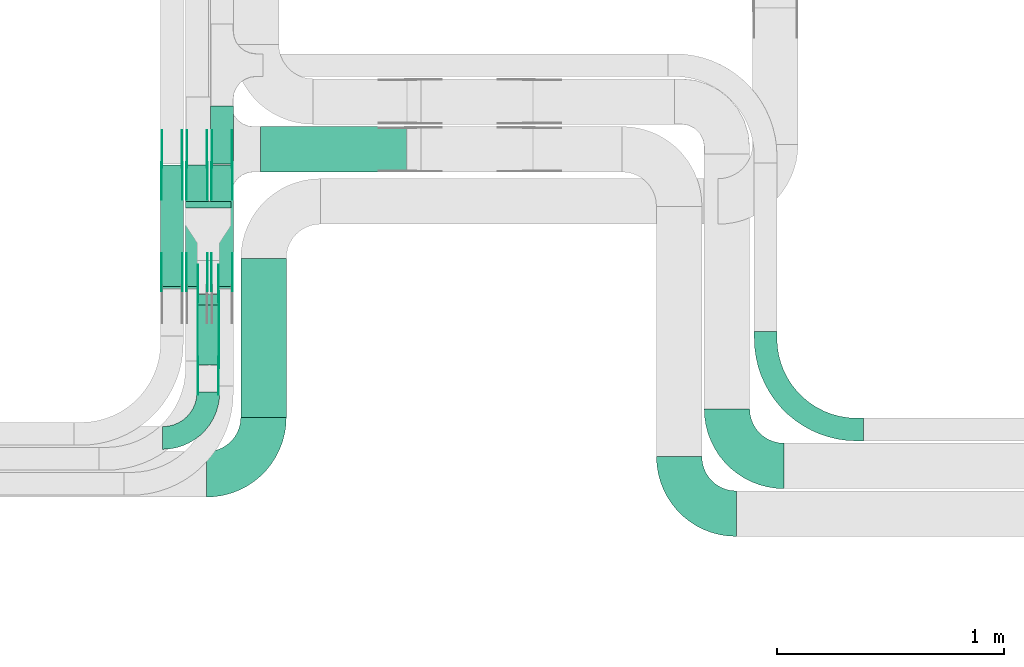
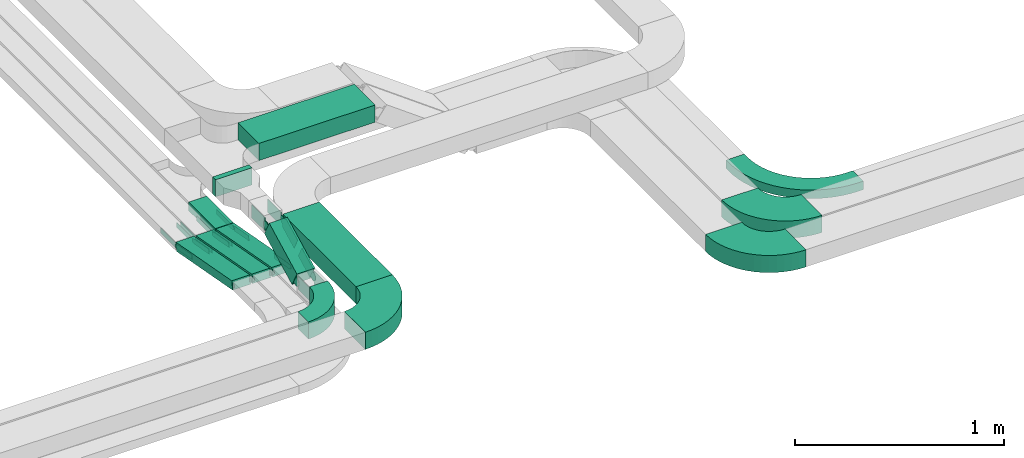
# One storey, part 10 of 25: 31 flow fittings, 8 flow segments.
"""IFC2X3 building model written with IfcOpenShell, lengths in millimetres."""

from ifc_helpers import new_model, entity, si_unit, converted_unit, derived_unit, direction, frame, frame_2d, origin, origin_2d_with_axis, place, context, subcontext, project, spatial, polyline, circle_curve, parameter, trimmed, segment, composite_curve, rectangle, outline, extrude, source, transform, mapped, material, type_object, type_shapes, element, save


model = new_model("IFC2X3")

# Units and contexts
model_context = context("Model", 3, precision=0.01, world=origin(), true_north=direction((6.12303176911189e-17, 1.0)))
body_context = subcontext(model_context, "Body", "Model", "MODEL_VIEW")
ifc_project = project(units=[si_unit("LENGTHUNIT", "METRE", prefix="MILLI"), si_unit("AREAUNIT", "SQUARE_METRE"), si_unit("VOLUMEUNIT", "CUBIC_METRE"), converted_unit("PLANEANGLEUNIT", "DEGREE", entity("IfcRatioMeasure", 0.0174532925199433), si_unit("PLANEANGLEUNIT", "RADIAN"), dimensions=[0, 0, 0, 0, 0, 0, 0]), si_unit("MASSUNIT", "GRAM", prefix="KILO"), derived_unit("MASSDENSITYUNIT", [(si_unit("MASSUNIT", "GRAM", prefix="KILO"), 1), (si_unit("LENGTHUNIT", "METRE"), -3)]), derived_unit("MOMENTOFINERTIAUNIT", [(si_unit("LENGTHUNIT", "METRE"), 4)]), si_unit("TIMEUNIT", "SECOND"), si_unit("FREQUENCYUNIT", "HERTZ"), si_unit("THERMODYNAMICTEMPERATUREUNIT", "DEGREE_CELSIUS"), derived_unit("THERMALTRANSMITTANCEUNIT", [(si_unit("MASSUNIT", "GRAM", prefix="KILO"), 1), (si_unit("THERMODYNAMICTEMPERATUREUNIT", "KELVIN"), -1), (si_unit("TIMEUNIT", "SECOND"), -3)]), derived_unit("VOLUMETRICFLOWRATEUNIT", [(si_unit("LENGTHUNIT", "METRE"), 3), (si_unit("TIMEUNIT", "SECOND"), -1)]), derived_unit("MASSFLOWRATEUNIT", [(si_unit("MASSUNIT", "GRAM", prefix="KILO"), 1), (si_unit("TIMEUNIT", "SECOND"), -1)]), derived_unit("ROTATIONALFREQUENCYUNIT", [(si_unit("TIMEUNIT", "SECOND"), -1)]), si_unit("ELECTRICCURRENTUNIT", "AMPERE"), si_unit("ELECTRICVOLTAGEUNIT", "VOLT"), si_unit("POWERUNIT", "WATT"), si_unit("FORCEUNIT", "NEWTON", prefix="KILO"), si_unit("ILLUMINANCEUNIT", "LUX"), si_unit("LUMINOUSFLUXUNIT", "LUMEN"), si_unit("LUMINOUSINTENSITYUNIT", "CANDELA"), derived_unit("USERDEFINED", [(si_unit("MASSUNIT", "GRAM", prefix="KILO"), -1), (si_unit("LENGTHUNIT", "METRE"), -2), (si_unit("TIMEUNIT", "SECOND"), 3), (si_unit("LUMINOUSFLUXUNIT", "LUMEN"), 1)]), derived_unit("LINEARVELOCITYUNIT", [(si_unit("LENGTHUNIT", "METRE"), 1), (si_unit("TIMEUNIT", "SECOND"), -1)]), si_unit("PRESSUREUNIT", "PASCAL"), derived_unit("USERDEFINED", [(si_unit("LENGTHUNIT", "METRE"), -2), (si_unit("MASSUNIT", "GRAM", prefix="KILO"), 1), (si_unit("TIMEUNIT", "SECOND"), -2)]), derived_unit("LINEARFORCEUNIT", [(si_unit("MASSUNIT", "GRAM", prefix="KILO"), 1), (si_unit("LENGTHUNIT", "METRE"), 1), (si_unit("TIMEUNIT", "SECOND"), -2), (si_unit("LENGTHUNIT", "METRE"), -1)]), derived_unit("PLANARFORCEUNIT", [(si_unit("MASSUNIT", "GRAM", prefix="KILO"), 1), (si_unit("LENGTHUNIT", "METRE"), 1), (si_unit("TIMEUNIT", "SECOND"), -2), (si_unit("LENGTHUNIT", "METRE"), -2)])], contexts=[model_context])

# Site, building, storey
site_placement = place(None, frame((0.0, -0.00077364408347762, 0.0)))
site = spatial("IfcSite", under=ifc_project, at=site_placement, CompositionType="ELEMENT")
building_placement = place(site_placement, origin())
building = spatial("IfcBuilding", under=site, at=building_placement, CompositionType="ELEMENT")
storey_placement = place(building_placement, frame((0.0, 0.0, 24000.0)))
storey = spatial("IfcBuildingStorey", under=building, at=storey_placement, CompositionType="ELEMENT", Elevation=24000.0)

# Flow segments
cable_carrier_segment_type = type_object("IfcCableCarrierSegmentType", PredefinedType="CABLETRAYSEGMENT")
flow_segment_1_placement = place(storey_placement, frame((33053.0827924389, 10611.4765215059, 2650.04095576845)))
element("IfcFlowSegment", 1, at=flow_segment_1_placement, inside=storey, type_object=cable_carrier_segment_type, context=body_context, shape_type="SweptSolid", body=[
    extrude(rectangle(XDim=255.423874591191, YDim=100.000000000003, at=frame_2d((1.08002495835535e-12, -2.16715534406831e-12), x_axis=(1.0, 0.0))), frame((50.0, 127.711937295601, 0.0), z_axis=(0.0, 0.0, 1.0), x_axis=(0.0, -1.0, 0.0)), (0.0, 0.0, 1.0), 49.9999999999973),
])
flow_segment_2_placement = place(storey_placement, frame((32833.0827924389, 10064.8940567036, 2651.07777631369)))
element("IfcFlowSegment", 2, at=flow_segment_2_placement, inside=storey, type_object=cable_carrier_segment_type, context=body_context, shape_type="SweptSolid", body=[
    extrude(rectangle(XDim=49.999999999997, YDim=543.827941763907, at=frame_2d((-1.05160324892495e-12, -1.93622895494627e-13), x_axis=(0.0, 1.0))), frame((0.0, 271.936643524978, 73.9222236863096), z_axis=(1.0, 0.0, 0.0), x_axis=(0.0, 0.983401255749196, -0.18144412415646)), (0.0, 0.0, 1.0), 100.000000000003),
])
for number, where in (
    (3, (32943.0827924389, 10064.8940567036, 2651.07777631369)),
    (4, (33053.0827924389, 10064.8940567036, 2651.07777631369)),
):
    element("IfcFlowSegment", number, at=place(storey_placement, frame(where)), inside=storey, type_object=cable_carrier_segment_type, context=body_context, shape_type="SweptSolid", body=[
        extrude(rectangle(XDim=49.999999999997, YDim=543.8279417639, at=frame_2d((0.0, 0.0), x_axis=(0.0, 1.0))), frame((0.0, 271.936643524971, 73.9222236863096), z_axis=(1.0, 0.0, 0.0), x_axis=(0.0, 0.983401255749195, -0.181444124156462)), (0.0, 0.0, 1.0), 100.000000000003),
    ])
flow_segment_3_placement = place(storey_placement, frame((32943.0827924389, 10418.7124766457, 3040.0)))
element("IfcFlowSegment", 5, at=flow_segment_3_placement, inside=storey, type_object=cable_carrier_segment_type, context=body_context, shape_type="SweptSolid", body=[
    extrude(rectangle(XDim=28.1879194516785, YDim=199.999999999998, at=frame_2d((1.08268949361445e-12, 4.33431068813661e-12), x_axis=(1.0, 0.0))), frame((100.0, 14.0939597258404, 0.0), z_axis=(0.0, 0.0, 1.0), x_axis=(0.0, -1.0, 0.0)), (0.0, 0.0, 1.0), 100.000000000003),
])
flow_segment_4_placement = place(storey_placement, frame((33273.0827924389, 10576.9003960973, 3040.0)))
element("IfcFlowSegment", 6, at=flow_segment_4_placement, inside=storey, type_object=cable_carrier_segment_type, context=body_context, shape_type="SweptSolid", body=[
    extrude(rectangle(XDim=641.371886509749, YDim=200.000000000002, at=frame_2d((2.1600499167107e-12, 1.08713038571295e-12), x_axis=(1.0, 0.0))), frame((320.685943254872, 100.0, 0.0)), (0.0, 0.0, 1.0), 100.000000000008),
])
flow_segment_5_placement = place(storey_placement, frame((32993.082792439, 9729.37885631118, 2902.16180601824)))
element("IfcFlowSegment", 7, at=flow_segment_5_placement, inside=storey, type_object=cable_carrier_segment_type, context=body_context, shape_type="SweptSolid", body=[
    extrude(rectangle(XDim=100.000000000008, YDim=100.000000000003, at=origin_2d_with_axis()), frame((50.0, 23.0412932838562, 44.3745287727967), z_axis=(0.0, 0.887490575455865, 0.460825865677067), x_axis=(0.0, -0.460825865677067, 0.887490575455865)), (0.0, 0.0, 1.0), 297.134645895809),
])
flow_segment_6_placement = place(storey_placement, frame((33185.8855251231, 9498.82356382277, 2890.0)))
element("IfcFlowSegment", 8, at=flow_segment_6_placement, inside=storey, type_object=cable_carrier_segment_type, context=body_context, shape_type="SweptSolid", body=[
    extrude(rectangle(XDim=698.000000000018, YDim=199.999999999998, at=frame_2d((-5.40012479177676e-13, 0.0), x_axis=(1.0, 0.0))), frame((100.0, 349.0, 0.0), z_axis=(0.0, 0.0, 1.0), x_axis=(0.0, 1.0, 0.0)), (0.0, 0.0, 1.0), 100.000000000003),
])

# Flow fittings
ifc_material_1 = material(Name="G")
cable_carrier_fitting_type_1 = type_object("IfcCableCarrierFittingType", PredefinedType="NOTDEFINED", material=ifc_material_1)
shared_shape_1 = source(origin(), body_context, "Body", "SweptSolid", [
    extrude(outline(composite_curve([segment(trimmed(circle_curve(frame_2d((-44.5901162790698, 0.0), x_axis=(1.0, 0.0)), 12.5), [parameter(90.0000000000007)], [parameter(270.0)], True, "PARAMETER"), True, "CONTINUOUS"), segment(polyline([(-44.5901162790697, -12.5), (-33.0901162790698, -12.5)]), True, "CONTINUOUS"), segment(polyline([(-33.0901162790698, -12.5), (-31.2296511627907, -14.5)]), True, "CONTINUOUS"), segment(polyline([(-31.2296511627907, -14.5), (108.90988372093, -14.5)]), True, "CONTINUOUS"), segment(polyline([(108.90988372093, -14.5), (108.90988372093, 14.5)]), True, "CONTINUOUS"), segment(polyline([(108.90988372093, 14.5), (-31.2296511627907, 14.5)]), True, "CONTINUOUS"), segment(polyline([(-31.2296511627907, 14.5), (-33.0901162790698, 12.5)]), True, "CONTINUOUS"), segment(polyline([(-33.0901162790698, 12.5), (-44.5901162790699, 12.5)]), True, "CONTINUOUS")], self_intersect=False)), frame((44.5901162790698, 0.0, 0.0), z_axis=(0.0, 0.0, -1.0), x_axis=(1.0, 0.0, 0.0)), (0.0, 0.0, -1.0), 2.0),
])
type_shapes(cable_carrier_fitting_type_1, [shared_shape_1])
for number, where, z_axis, x_axis in (
    (9, (32837.6227924287, 10065.8378366345, 2775.0), (-1.0, 0.0, 0.0), (0.0, 0.983401255749196, -0.181444124156458)),
    (10, (32837.6227924287, 10607.8235638226, 2675.0), (-1.0, 0.0, 0.0), (0.0, -0.983401255749196, 0.181444124156458)),
    (11, (32947.6227924287, 10065.8378366345, 2775.0), (-1.0, 0.0, 0.0), (0.0, 0.983401255749196, -0.181444124156458)),
    (12, (32947.6227924287, 10607.8235638226, 2675.0), (-1.0, 0.0, 0.0), (0.0, -0.983401255749196, 0.181444124156458)),
    (13, (33057.6227924287, 10065.8378366345, 2775.0), (-1.0, 0.0, 0.0), (0.0, 0.983401255749196, -0.181444124156458)),
    (14, (33057.6227924287, 10607.8235638226, 2675.0), (-1.0, 0.0, 0.0), (0.0, -0.983401255749196, 0.181444124156458)),
):
    element("IfcFlowFitting", number, at=place(storey_placement, frame(where, z_axis=z_axis, x_axis=x_axis)), inside=storey, type_object=cable_carrier_fitting_type_1, material=ifc_material_1, context=body_context, shape_type="MappedRepresentation", body=[
        mapped(shared_shape_1, transform((0.0, 0.0, 0.0), scale=1.0)),
    ])
cable_carrier_fitting_type_2 = type_object("IfcCableCarrierFittingType", PredefinedType="NOTDEFINED", material=ifc_material_1)
shared_shape_2 = source(origin(), body_context, "Body", "SweptSolid", [
    extrude(outline(composite_curve([segment(trimmed(circle_curve(frame_2d((-44.5901162790697, 0.0), x_axis=(1.0, 0.0)), 12.5), [parameter(90.0000000000007)], [parameter(270.0)], True, "PARAMETER"), True, "CONTINUOUS"), segment(polyline([(-44.5901162790697, -12.5), (-33.0901162790697, -12.5)]), True, "CONTINUOUS"), segment(polyline([(-33.0901162790697, -12.5), (-31.2296511627907, -14.5)]), True, "CONTINUOUS"), segment(polyline([(-31.2296511627907, -14.5), (108.90988372093, -14.5)]), True, "CONTINUOUS"), segment(polyline([(108.90988372093, -14.5), (108.90988372093, 14.5)]), True, "CONTINUOUS"), segment(polyline([(108.90988372093, 14.5), (-31.2296511627907, 14.5)]), True, "CONTINUOUS"), segment(polyline([(-31.2296511627907, 14.5), (-33.0901162790698, 12.5)]), True, "CONTINUOUS"), segment(polyline([(-33.0901162790698, 12.5), (-44.5901162790699, 12.5)]), True, "CONTINUOUS")], self_intersect=False)), frame((44.5901162790697, 0.0, 0.0)), (0.0, 0.0, 1.0), 2.0),
])
type_shapes(cable_carrier_fitting_type_2, [shared_shape_2])
for number, where, z_axis, x_axis in (
    (15, (32928.542792449, 10065.8378366345, 2775.0), (1.0, 0.0, 0.0), (0.0, 0.983401255749196, -0.181444124156458)),
    (16, (32928.542792449, 10607.8235638226, 2675.0), (1.0, 0.0, 0.0), (0.0, -0.983401255749196, 0.181444124156458)),
    (17, (33038.542792449, 10065.8378366345, 2775.0), (1.0, 0.0, 0.0), (0.0, 0.983401255749196, -0.181444124156458)),
    (18, (33038.542792449, 10607.8235638226, 2675.0), (1.0, 0.0, 0.0), (0.0, -0.983401255749196, 0.181444124156458)),
    (19, (33148.542792449, 10065.8378366345, 2775.0), (1.0, 0.0, 0.0), (0.0, 0.983401255749196, -0.181444124156458)),
    (20, (33148.542792449, 10607.8235638226, 2675.0), (1.0, 0.0, 0.0), (0.0, -0.983401255749196, 0.181444124156458)),
):
    element("IfcFlowFitting", number, at=place(storey_placement, frame(where, z_axis=z_axis, x_axis=x_axis)), inside=storey, type_object=cable_carrier_fitting_type_2, material=ifc_material_1, context=body_context, shape_type="MappedRepresentation", body=[
        mapped(shared_shape_2, transform((0.0, 0.0, 0.0), scale=1.0)),
    ])
cable_carrier_fitting_type_3 = type_object("IfcCableCarrierFittingType", PredefinedType="NOTDEFINED", material=ifc_material_1)
shared_shape_3 = source(origin(), body_context, "Body", "SweptSolid", [
    extrude(outline(composite_curve([segment(trimmed(circle_curve(frame_2d((-44.5901162790698, 0.0), x_axis=(1.0, 0.0)), 12.5), [parameter(90.0000000000007)], [parameter(270.0)], True, "PARAMETER"), True, "CONTINUOUS"), segment(polyline([(-44.5901162790697, -12.5), (-33.0901162790698, -12.5)]), True, "CONTINUOUS"), segment(polyline([(-33.0901162790698, -12.5), (-31.2296511627907, -14.5)]), True, "CONTINUOUS"), segment(polyline([(-31.2296511627907, -14.5), (108.90988372093, -14.5)]), True, "CONTINUOUS"), segment(polyline([(108.90988372093, -14.5), (108.90988372093, 14.5)]), True, "CONTINUOUS"), segment(polyline([(108.90988372093, 14.5), (-31.2296511627907, 14.5)]), True, "CONTINUOUS"), segment(polyline([(-31.2296511627907, 14.5), (-33.0901162790698, 12.5)]), True, "CONTINUOUS"), segment(polyline([(-33.0901162790698, 12.5), (-44.5901162790699, 12.5)]), True, "CONTINUOUS")], self_intersect=False)), frame((44.5901162790698, 0.0, 0.0), z_axis=(0.0, 0.0, -1.0), x_axis=(1.0, 0.0, 0.0)), (0.0, 0.0, -1.0), 2.0),
])
type_shapes(cable_carrier_fitting_type_3, [shared_shape_3])
for number, where, z_axis, x_axis in (
    (21, (32926.542792449, 10607.8235638226, 2675.0), (1.0, 0.0, 0.0), (0.0, 1.0, 0.0)),
    (22, (33036.542792449, 10607.8235638226, 2675.0), (1.0, 0.0, 0.0), (0.0, 1.0, 0.0)),
    (23, (33146.542792449, 10607.8235638226, 2675.0), (1.0, 0.0, 0.0), (0.0, 1.0, 0.0)),
):
    element("IfcFlowFitting", number, at=place(storey_placement, frame(where, z_axis=z_axis, x_axis=x_axis)), inside=storey, type_object=cable_carrier_fitting_type_3, material=ifc_material_1, context=body_context, shape_type="MappedRepresentation", body=[
        mapped(shared_shape_3, transform((0.0, 0.0, 0.0), scale=1.0)),
    ])
cable_carrier_fitting_type_4 = type_object("IfcCableCarrierFittingType", PredefinedType="NOTDEFINED", material=ifc_material_1)
shared_shape_4 = source(origin(), body_context, "Body", "SweptSolid", [
    extrude(outline(composite_curve([segment(trimmed(circle_curve(frame_2d((-44.5901162790697, 0.0), x_axis=(1.0, 0.0)), 12.5), [parameter(90.0000000000007)], [parameter(270.0)], True, "PARAMETER"), True, "CONTINUOUS"), segment(polyline([(-44.5901162790697, -12.5), (-33.0901162790697, -12.5)]), True, "CONTINUOUS"), segment(polyline([(-33.0901162790697, -12.5), (-31.2296511627907, -14.5)]), True, "CONTINUOUS"), segment(polyline([(-31.2296511627907, -14.5), (108.90988372093, -14.5)]), True, "CONTINUOUS"), segment(polyline([(108.90988372093, -14.5), (108.90988372093, 14.5)]), True, "CONTINUOUS"), segment(polyline([(108.90988372093, 14.5), (-31.2296511627907, 14.5)]), True, "CONTINUOUS"), segment(polyline([(-31.2296511627907, 14.5), (-33.0901162790698, 12.5)]), True, "CONTINUOUS"), segment(polyline([(-33.0901162790698, 12.5), (-44.5901162790699, 12.5)]), True, "CONTINUOUS")], self_intersect=False)), frame((44.5901162790697, 0.0, 0.0)), (0.0, 0.0, 1.0), 2.0),
])
type_shapes(cable_carrier_fitting_type_4, [shared_shape_4])
for number, where, z_axis, x_axis in (
    (24, (32839.6227924287, 10607.8235638226, 2675.0), (-1.0, 0.0, 0.0), (0.0, 1.0, 0.0)),
    (25, (32949.6227924287, 10607.8235638226, 2675.0), (-1.0, 0.0, 0.0), (0.0, 1.0, 0.0)),
    (26, (33059.6227924287, 10607.8235638226, 2675.0), (-1.0, 0.0, 0.0), (0.0, 1.0, 0.0)),
):
    element("IfcFlowFitting", number, at=place(storey_placement, frame(where, z_axis=z_axis, x_axis=x_axis)), inside=storey, type_object=cable_carrier_fitting_type_4, material=ifc_material_1, context=body_context, shape_type="MappedRepresentation", body=[
        mapped(shared_shape_4, transform((0.0, 0.0, 0.0), scale=1.0)),
    ])
cable_carrier_fitting_type_5 = type_object("IfcCableCarrierFittingType", PredefinedType="NOTDEFINED", material=ifc_material_1)
shared_shape_5 = source(origin(), body_context, "Body", "SweptSolid", [
    extrude(outline(composite_curve([segment(trimmed(circle_curve(frame_2d((-41.4651162790697, 0.0), x_axis=(1.0, 0.0)), 25.0), [parameter(90.0000000000007)], [parameter(270.0)], True, "PARAMETER"), True, "CONTINUOUS"), segment(polyline([(-41.4651162790697, -25.0), (-29.9651162790697, -25.0)]), True, "CONTINUOUS"), segment(polyline([(-29.9651162790697, -25.0), (-28.1046511627907, -38.5)]), True, "CONTINUOUS"), segment(polyline([(-28.1046511627907, -38.5), (99.5348837209303, -38.5)]), True, "CONTINUOUS"), segment(polyline([(99.5348837209303, -38.5), (99.5348837209303, 38.5)]), True, "CONTINUOUS"), segment(polyline([(99.5348837209303, 38.5), (-28.1046511627907, 38.5)]), True, "CONTINUOUS"), segment(polyline([(-28.1046511627907, 38.5), (-29.9651162790697, 25.0)]), True, "CONTINUOUS"), segment(polyline([(-29.9651162790697, 25.0), (-41.46511627907, 25.0)]), True, "CONTINUOUS")], self_intersect=False)), frame((41.4651162790697, 0.0, 0.0), z_axis=(0.0, 0.0, -1.0), x_axis=(1.0, 0.0, 0.0)), (0.0, 0.0, -1.0), 2.0),
])
type_shapes(cable_carrier_fitting_type_5, [shared_shape_5])
for number, where, z_axis, x_axis in (
    (27, (33088.5427924491, 10028.7124766456, 3090.0), (1.0, 0.0, 0.0), (0.0, -0.887490575455891, -0.460825865677017)),
    (28, (33088.5427924491, 9739.83202041837, 2940.0), (1.0, 0.0, 0.0), (0.0, 0.887490575455891, 0.460825865677017)),
):
    element("IfcFlowFitting", number, at=place(storey_placement, frame(where, z_axis=z_axis, x_axis=x_axis)), inside=storey, type_object=cable_carrier_fitting_type_5, material=ifc_material_1, context=body_context, shape_type="MappedRepresentation", body=[
        mapped(shared_shape_5, transform((0.0, 0.0, 0.0), scale=1.0)),
    ])
cable_carrier_fitting_type_6 = type_object("IfcCableCarrierFittingType", PredefinedType="NOTDEFINED", material=ifc_material_1)
shared_shape_6 = source(origin(), body_context, "Body", "SweptSolid", [
    extrude(outline(composite_curve([segment(trimmed(circle_curve(frame_2d((-41.4651162790697, 0.0), x_axis=(1.0, 0.0)), 25.0), [parameter(90.0000000000007)], [parameter(270.0)], True, "PARAMETER"), True, "CONTINUOUS"), segment(polyline([(-41.4651162790697, -25.0), (-29.9651162790697, -25.0)]), True, "CONTINUOUS"), segment(polyline([(-29.9651162790697, -25.0), (-28.1046511627907, -38.5)]), True, "CONTINUOUS"), segment(polyline([(-28.1046511627907, -38.5), (99.5348837209303, -38.5)]), True, "CONTINUOUS"), segment(polyline([(99.5348837209303, -38.5), (99.5348837209303, 38.5)]), True, "CONTINUOUS"), segment(polyline([(99.5348837209303, 38.5), (-28.1046511627907, 38.5)]), True, "CONTINUOUS"), segment(polyline([(-28.1046511627907, 38.5), (-29.9651162790697, 25.0)]), True, "CONTINUOUS"), segment(polyline([(-29.9651162790697, 25.0), (-41.46511627907, 25.0)]), True, "CONTINUOUS")], self_intersect=False)), frame((41.4651162790697, 0.0, 0.0)), (0.0, 0.0, 1.0), 2.0),
])
type_shapes(cable_carrier_fitting_type_6, [shared_shape_6])
for number, where, z_axis, x_axis in (
    (29, (32997.6227924288, 10028.7124766456, 3090.0), (-1.0, 0.0, 0.0), (0.0, -0.887490575455891, -0.460825865677017)),
    (30, (32997.6227924288, 9739.83202041837, 2940.0), (-1.0, 0.0, 0.0), (0.0, 0.887490575455891, 0.460825865677017)),
):
    element("IfcFlowFitting", number, at=place(storey_placement, frame(where, z_axis=z_axis, x_axis=x_axis)), inside=storey, type_object=cable_carrier_fitting_type_6, material=ifc_material_1, context=body_context, shape_type="MappedRepresentation", body=[
        mapped(shared_shape_6, transform((0.0, 0.0, 0.0), scale=1.0)),
    ])
cable_carrier_fitting_type_7 = type_object("IfcCableCarrierFittingType", PredefinedType="NOTDEFINED", material=ifc_material_1)
shared_shape_7 = source(origin(), body_context, "Body", "SweptSolid", [
    extrude(outline(composite_curve([segment(trimmed(circle_curve(frame_2d((-41.4651162790697, 0.0), x_axis=(1.0, 0.0)), 25.0), [parameter(90.0000000000007)], [parameter(270.0)], True, "PARAMETER"), True, "CONTINUOUS"), segment(polyline([(-41.4651162790697, -25.0), (-29.9651162790697, -25.0)]), True, "CONTINUOUS"), segment(polyline([(-29.9651162790697, -25.0), (-28.1046511627907, -38.5)]), True, "CONTINUOUS"), segment(polyline([(-28.1046511627907, -38.5), (99.5348837209303, -38.5)]), True, "CONTINUOUS"), segment(polyline([(99.5348837209303, -38.5), (99.5348837209303, 38.5)]), True, "CONTINUOUS"), segment(polyline([(99.5348837209303, 38.5), (-28.1046511627907, 38.5)]), True, "CONTINUOUS"), segment(polyline([(-28.1046511627907, 38.5), (-29.9651162790697, 25.0)]), True, "CONTINUOUS"), segment(polyline([(-29.9651162790697, 25.0), (-41.46511627907, 25.0)]), True, "CONTINUOUS")], self_intersect=False)), frame((41.4651162790697, 0.0, 0.0), z_axis=(0.0, 0.0, -1.0), x_axis=(1.0, 0.0, 0.0)), (0.0, 0.0, -1.0), 2.0),
])
type_shapes(cable_carrier_fitting_type_7, [shared_shape_7])
for number, where, z_axis, x_axis in (
    (31, (32999.6227924288, 10028.7124766456, 3090.0), (-1.0, 0.0, 0.0), (0.0, 1.0, 0.0)),
    (32, (32999.6227924288, 9739.83202041838, 2940.0), (-1.0, 0.0, 0.0), (0.0, -1.0, 0.0)),
):
    element("IfcFlowFitting", number, at=place(storey_placement, frame(where, z_axis=z_axis, x_axis=x_axis)), inside=storey, type_object=cable_carrier_fitting_type_7, material=ifc_material_1, context=body_context, shape_type="MappedRepresentation", body=[
        mapped(shared_shape_7, transform((0.0, 0.0, 0.0), scale=1.0)),
    ])
cable_carrier_fitting_type_8 = type_object("IfcCableCarrierFittingType", PredefinedType="NOTDEFINED", material=ifc_material_1)
shared_shape_8 = source(origin(), body_context, "Body", "SweptSolid", [
    extrude(outline(composite_curve([segment(trimmed(circle_curve(frame_2d((-41.4651162790697, 0.0), x_axis=(1.0, 0.0)), 25.0), [parameter(90.0000000000007)], [parameter(270.0)], True, "PARAMETER"), True, "CONTINUOUS"), segment(polyline([(-41.4651162790697, -25.0), (-29.9651162790697, -25.0)]), True, "CONTINUOUS"), segment(polyline([(-29.9651162790697, -25.0), (-28.1046511627907, -38.5)]), True, "CONTINUOUS"), segment(polyline([(-28.1046511627907, -38.5), (99.5348837209303, -38.5)]), True, "CONTINUOUS"), segment(polyline([(99.5348837209303, -38.5), (99.5348837209303, 38.5)]), True, "CONTINUOUS"), segment(polyline([(99.5348837209303, 38.5), (-28.1046511627907, 38.5)]), True, "CONTINUOUS"), segment(polyline([(-28.1046511627907, 38.5), (-29.9651162790697, 25.0)]), True, "CONTINUOUS"), segment(polyline([(-29.9651162790697, 25.0), (-41.46511627907, 25.0)]), True, "CONTINUOUS")], self_intersect=False)), frame((41.4651162790697, 0.0, 0.0)), (0.0, 0.0, 1.0), 2.0),
])
type_shapes(cable_carrier_fitting_type_8, [shared_shape_8])
for number, where, z_axis, x_axis in (
    (33, (33086.5427924491, 10028.7124766456, 3090.0), (1.0, 0.0, 0.0), (0.0, 1.0, 0.0)),
    (34, (33086.5427924491, 9739.83202041838, 2940.0), (1.0, 0.0, 0.0), (0.0, -1.0, 0.0)),
):
    element("IfcFlowFitting", number, at=place(storey_placement, frame(where, z_axis=z_axis, x_axis=x_axis)), inside=storey, type_object=cable_carrier_fitting_type_8, material=ifc_material_1, context=body_context, shape_type="MappedRepresentation", body=[
        mapped(shared_shape_8, transform((0.0, 0.0, 0.0), scale=1.0)),
    ])
ifc_material_2 = material()
cable_carrier_fitting_type_9 = type_object("IfcCableCarrierFittingType", Name="470_DKC_S5_Variable Angle Elbow 0-45:-", PredefinedType="NOTDEFINED", material=ifc_material_2)
shared_shape_9 = source(origin(), body_context, "Body", "SweptSolid", [
    extrude(outline(composite_curve([segment(polyline([(-125.750000000001, -225.25), (-124.749999999999, -225.25)]), True, "CONTINUOUS"), segment(trimmed(circle_curve(frame_2d((-124.75, 124.75), x_axis=(0.0, -1.0)), 350.0), [parameter(0.0)], [parameter(90.0000000000001)], True, "PARAMETER"), True, "CONTINUOUS"), segment(polyline([(225.25, 124.75), (225.25, 125.749999999999)]), True, "CONTINUOUS"), segment(polyline([(225.25, 125.749999999999), (25.25, 125.750000000001)]), True, "CONTINUOUS"), segment(polyline([(25.25, 125.750000000001), (25.25, 124.75)]), True, "CONTINUOUS"), segment(trimmed(circle_curve(frame_2d((-124.75, 124.75), x_axis=(0.0, -1.0)), 150.0), [parameter(0.0)], [parameter(90.0000000000001)], True, "PARAMETER"), False, "CONTINUOUS"), segment(polyline([(-124.749999999999, -25.2500000000003), (-125.750000000001, -25.2500000000003)]), True, "CONTINUOUS"), segment(polyline([(-125.750000000001, -25.2500000000003), (-125.750000000001, -225.25)]), True, "CONTINUOUS")], self_intersect=False)), frame((-125.249999999991, 125.249999999992, -50.0)), (0.0, 0.0, 1.0), 100.0),
])
type_shapes(cable_carrier_fitting_type_9, [shared_shape_9])
flow_fitting_1_placement = place(storey_placement, frame((33285.8855251231, 9247.82356382279, 2940.0)))
element("IfcFlowFitting", 35, at=flow_fitting_1_placement, inside=storey, type_object=cable_carrier_fitting_type_9, material=ifc_material_2, Name="470_DKC_S5_Variable Angle Elbow 0-45:-", ObjectType="470_DKC_S5_Variable Angle Elbow 0-45:-", context=body_context, shape_type="MappedRepresentation", body=[
    mapped(shared_shape_9, transform((0.0, 0.0, 0.0), scale=1.0)),
])
for number, where, z_axis, x_axis, name in (
    (36, (35113.0827924389, 9074.94253623851, 2710.0), (0.0, 0.0, 1.0), (0.0, -1.0, 0.0), "470_DKC_S5_Variable Angle Elbow 0-45:-"),
    (37, (35323.0827924389, 9284.94253623852, 2710.0), (0.0, 0.0, 1.0), (0.0, -1.0, 0.0), "470_DKC_S5_Variable Angle Elbow 0-45:-"),
):
    element("IfcFlowFitting", number, at=place(storey_placement, frame(where, z_axis=z_axis, x_axis=x_axis)), inside=storey, type_object=cable_carrier_fitting_type_9, material=ifc_material_2, Name=name, ObjectType="470_DKC_S5_Variable Angle Elbow 0-45:-", context=body_context, shape_type="MappedRepresentation", body=[
        mapped(shared_shape_9, transform((0.0, 0.0, 0.0), scale=1.0)),
    ])
cable_carrier_fitting_type_10 = type_object("IfcCableCarrierFittingType", Name="470_DKC_S5_CPO 45 horizontal angle:-", PredefinedType="NOTDEFINED", material=ifc_material_2)
shared_shape_10 = source(origin(), body_context, "Body", "SweptSolid", [
    extrude(outline(composite_curve([segment(polyline([(-222.5, -257.5), (-192.5, -257.5)]), True, "CONTINUOUS"), segment(trimmed(circle_curve(frame_2d((-192.5, 192.5), x_axis=(0.0, -1.0)), 450.0), [parameter(0.0)], [parameter(90.0)], True, "PARAMETER"), True, "CONTINUOUS"), segment(polyline([(257.5, 192.5), (257.5, 222.5)]), True, "CONTINUOUS"), segment(polyline([(257.5, 222.5), (157.5, 222.5)]), True, "CONTINUOUS"), segment(polyline([(157.5, 222.5), (157.5, 192.5)]), True, "CONTINUOUS"), segment(trimmed(circle_curve(frame_2d((-192.5, 192.5), x_axis=(0.0, -1.0)), 350.0), [parameter(0.0)], [parameter(90.0)], True, "PARAMETER"), False, "CONTINUOUS"), segment(polyline([(-192.5, -157.5), (-222.5, -157.5)]), True, "CONTINUOUS"), segment(polyline([(-222.5, -157.5), (-222.5, -257.5)]), True, "CONTINUOUS")], self_intersect=False)), frame((-207.499999999991, 207.499999999992, -25.0)), (0.0, 0.0, 1.0), 50.0000000000002),
])
type_shapes(cable_carrier_fitting_type_10, [shared_shape_10])
flow_fitting_2_placement = place(storey_placement, frame((35493.0827924389, 9444.9425362387, 2685.0), z_axis=(0.0, 0.0, 1.0), x_axis=(0.0, -1.0, 0.0)))
element("IfcFlowFitting", 38, at=flow_fitting_2_placement, inside=storey, type_object=cable_carrier_fitting_type_10, material=ifc_material_2, Name="470_DKC_S5_45 horizontal angle", ObjectType="470_DKC_S5_CPO 45 horizontal angle:-", context=body_context, shape_type="MappedRepresentation", body=[
    mapped(shared_shape_10, transform((0.0, 0.0, 0.0), scale=1.0)),
])
cable_carrier_fitting_type_11 = type_object("IfcCableCarrierFittingType", Name="470_DKC_S5_Variable Angle Elbow 0-45:-", PredefinedType="NOTDEFINED", material=ifc_material_2)
shared_shape_11 = source(origin(), body_context, "Body", "SweptSolid", [
    extrude(outline(composite_curve([segment(polyline([(-100.749999999999, -150.250000000001), (-99.7499999999981, -150.250000000001)]), True, "CONTINUOUS"), segment(trimmed(circle_curve(frame_2d((-99.7500000000006, 99.7499999999987), x_axis=(0.0, -1.0)), 250.0), [parameter(0.0)], [parameter(90.0000000000001)], True, "PARAMETER"), True, "CONTINUOUS"), segment(polyline([(150.249999999999, 99.7500000000013), (150.249999999999, 100.750000000001)]), True, "CONTINUOUS"), segment(polyline([(150.249999999999, 100.750000000001), (50.2499999999992, 100.750000000001)]), True, "CONTINUOUS"), segment(polyline([(50.2499999999992, 100.750000000001), (50.2499999999992, 99.7500000000002)]), True, "CONTINUOUS"), segment(trimmed(circle_curve(frame_2d((-99.7500000000006, 99.7499999999987), x_axis=(0.0, -1.0)), 150.0), [parameter(0.0)], [parameter(90.0000000000001)], True, "PARAMETER"), False, "CONTINUOUS"), segment(polyline([(-99.7499999999989, -50.2500000000011), (-100.75, -50.2500000000011)]), True, "CONTINUOUS"), segment(polyline([(-100.75, -50.2500000000011), (-100.749999999999, -150.250000000001)]), True, "CONTINUOUS")], self_intersect=False)), frame((-100.249999999991, 100.249999999992, -50.0)), (0.0, 0.0, 1.0), 100.0),
])
type_shapes(cable_carrier_fitting_type_11, [shared_shape_11])
flow_fitting_3_placement = place(storey_placement, frame((33043.0827924391, 9407.82356382268, 2940.0)))
element("IfcFlowFitting", 39, at=flow_fitting_3_placement, inside=storey, type_object=cable_carrier_fitting_type_11, material=ifc_material_2, Name="470_DKC_S5_Variable Angle Elbow 0-45:-", ObjectType="470_DKC_S5_Variable Angle Elbow 0-45:-", context=body_context, shape_type="MappedRepresentation", body=[
    mapped(shared_shape_11, transform((0.0, 0.0, 0.0), scale=1.0)),
])

save(model, "model.ifc")
